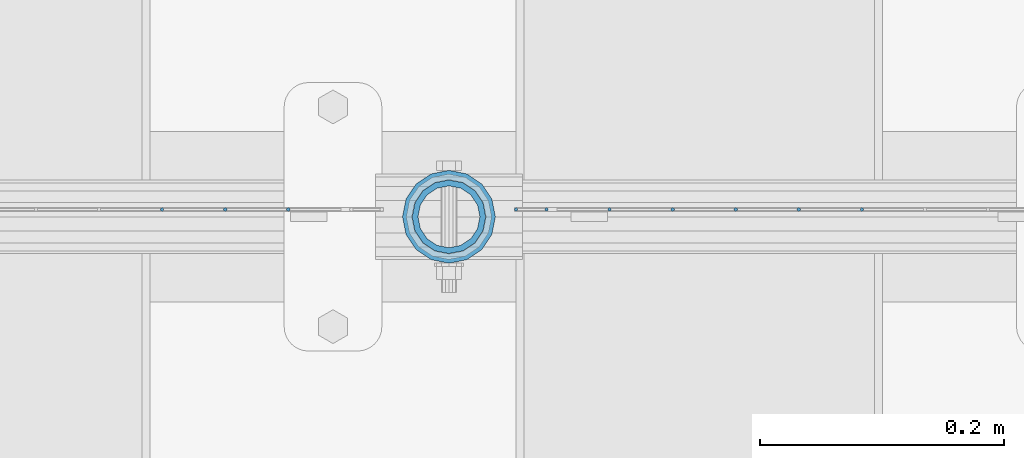
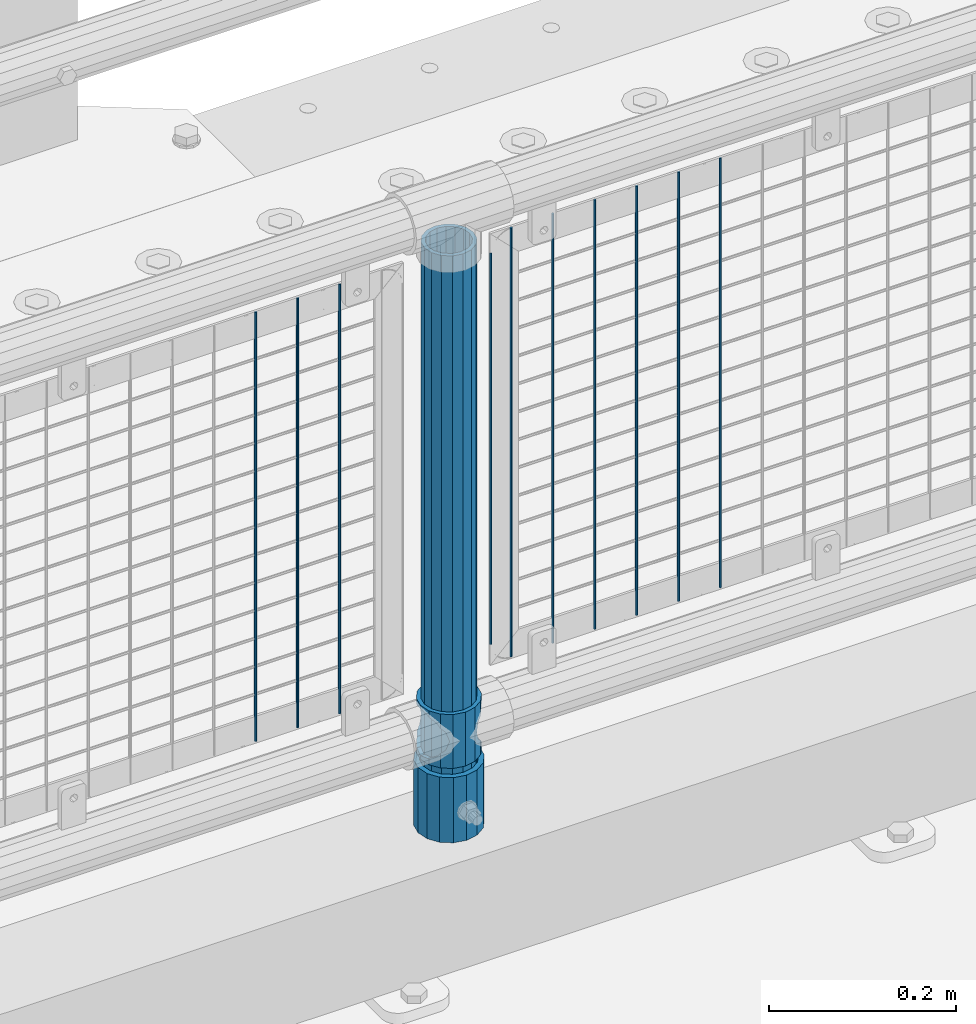
# One storey, part 63 of 193: 13 columns.
"""IFC2X3 building model written with IfcOpenShell, lengths in millimetres."""

from ifc_helpers import new_model, si_unit, frame, origin_with_axes, place, context, subcontext, project, spatial, faceted_brep, material, type_object, element, save


model = new_model("IFC2X3")

# Units and contexts
model_context = context("Model", 3, precision=1e-05, world=origin_with_axes())
body_context = subcontext(model_context, "Body", "Model", "MODEL_VIEW")
ifc_project = project(units=[si_unit("LENGTHUNIT", "METRE", prefix="MILLI"), si_unit("AREAUNIT", "SQUARE_METRE"), si_unit("VOLUMEUNIT", "CUBIC_METRE"), si_unit("MASSUNIT", "GRAM", prefix="KILO"), si_unit("TIMEUNIT", "SECOND"), si_unit("PLANEANGLEUNIT", "RADIAN"), si_unit("SOLIDANGLEUNIT", "STERADIAN"), si_unit("THERMODYNAMICTEMPERATUREUNIT", "DEGREE_CELSIUS"), si_unit("LUMINOUSINTENSITYUNIT", "LUMEN")], contexts=[model_context])

# Site, building, storey
site_placement = place(None, origin_with_axes())
site = spatial("IfcSite", under=ifc_project, at=site_placement, CompositionType="ELEMENT")
building_placement = place(site_placement, origin_with_axes())
building = spatial("IfcBuilding", under=site, at=building_placement, Name="Standard", CompositionType="ELEMENT")
storey_placement = place(building_placement, origin_with_axes())
storey = spatial("IfcBuildingStorey", under=building, at=storey_placement, Name="Undefined", CompositionType="ELEMENT", Elevation=0.0)

# Columns
ifc_material_1 = material(Name="Misc_Undefined")
column_type_1 = type_object("IfcColumnType", PredefinedType="NOTDEFINED")
column_1_placement = place(storey_placement, frame((-36855.0, 28664.5, 263.020000000001), z_axis=(-1.0, 0.0, 0.0), x_axis=(0.0, 0.0, 1.0)))
element("IfcColumn", 1, at=column_1_placement, inside=storey, type_object=column_type_1, material=ifc_material_1, context=body_context, shape_type="Brep", body=[
    faceted_brep([(56.6106908090114, 21.46069080901, -21.46069080901), (56.6106908090114, 21.46069080901, -27.1226768591041), (61.9623795176744, 13.4513226476338, -32.4743655677703), (63.1897438117172, 11.614442172282, -32.8397438117245), (63.1897438117172, 11.614442172282, -28.0397438117179), (46.7644421722801, 28.0397438117179, -11.614442172282), (46.7644421722801, 28.0397438117179, -20.0882031229849), (51.5310424080006, 24.8548033587067, -24.8548033587067), (35.1500000000015, 30.35, 0.0), (35.1499999999996, 30.3499999999985, -16.6306603983685), (23.5355578277192, 28.0397438117179, -11.614442172282), (23.5355578277192, 28.0397438117179, -20.0882031229849), (13.6893091909879, 21.46069080901, -21.46069080901), (13.6893091909879, 21.46069080901, -27.1226768591041), (18.7689575919987, 24.8548033587067, -24.8548033587067), (7.11025618828211, 11.614442172282, -28.0397438117179), (7.11025618828211, 11.614442172282, -32.8397438117245), (8.33762048232262, 13.4513226476338, -32.4743655677703), (4.79999999999961, 0.0, -30.3499999999985), (4.79999999999961, 0.0, -35.1500000000015), (7.11025618828211, -11.614442172282, -28.0397438117179), (7.11025618828211, -11.614442172282, -32.8397438117172), (13.6893091909879, -21.46069080901, -21.46069080901), (13.6893091909879, -21.46069080901, -27.1226768591114), (8.33762048232484, -13.4513226476338, -32.4743655677703), (23.5355578277191, -28.0397438117179, -11.614442172282), (23.5355578277191, -28.0397438117179, -20.0882031229812), (18.7689575919921, -24.8548033587067, -24.8548033587067), (35.1500000000015, -30.35, 0.0), (35.1499999999996, -30.3499999999985, -16.6306603983721), (46.7644421722801, -28.0397438117179, -11.614442172282), (46.7644421722801, -28.0397438117179, -20.0882031229812), (56.6106908090114, -21.46069080901, -21.46069080901), (56.6106908090114, -21.46069080901, -27.1226768591114), (51.5310424080006, -24.8548033587067, -24.8548033587067), (63.1897438117172, -11.614442172282, -28.0397438117179), (63.1897438117172, -11.614442172282, -32.8397438117172), (61.9623795176767, -13.4513226476338, -32.4743655677703), (65.4999999999997, 0.0, -30.3499999999985), (65.4999999999997, 0.0, -35.1500000000015), (0.0, -28.0397438117179, -11.614442172282), (0.0, -30.3499999999985, 0.0), (0.0, -21.46069080901, -21.46069080901), (0.0, -11.614442172282, -28.0397438117179), (0.0, 0.0, -30.3499999999985), (0.0, 11.614442172282, -28.0397438117179), (0.0, 21.46069080901, -21.46069080901), (0.0, 28.0397438117179, -11.614442172282), (0.0, 30.3499999999985, 0.0), (0.0, 28.0397438117179, 11.614442172282), (23.5355578277192, 28.0397438117179, 11.614442172282), (0.0, 21.46069080901, 21.46069080901), (13.6893091909879, 21.46069080901, 21.46069080901), (0.0, 11.614442172282, 28.0397438117179), (7.11025618828211, 11.614442172282, 28.0397438117179), (0.0, 0.0, 30.3499999999985), (4.79999999999961, 0.0, 30.3499999999985), (0.0, -11.614442172282, 28.0397438117179), (7.11025618828205, -11.614442172282, 28.0397438117179), (0.0, -21.46069080901, 21.46069080901), (13.6893091909879, -21.46069080901, 21.46069080901), (0.0, -28.0397438117179, 11.614442172282), (23.5355578277191, -28.0397438117179, 11.614442172282), (0.0, -32.4743655677703, 13.4513226476338), (0.0, -35.1500000000015, 0.0), (70.2999999999993, -35.1500000000015, 0.0), (70.2999999999993, -32.4743655677703, 13.4513226476338), (0.0, 13.4513226476338, -32.4743655677703), (0.0, 24.8548033587067, -24.8548033587067), (0.0, 0.0, -35.1500000000015), (0.0, -13.4513226476338, -32.4743655677703), (0.0, -24.8548033587067, -24.8548033587067), (0.0, -24.8548033587067, 24.8548033587067), (0.0, -13.4513226476338, 32.4743655677703), (0.0, 0.0, 35.1500000000015), (0.0, 13.4513226476338, 32.4743655677703), (0.0, 24.8548033587067, 24.8548033587067), (0.0, 32.4743655677703, 13.4513226476338), (0.0, 35.1500000000015, 0.0), (0.0, 32.4743655677703, -13.4513226476338), (0.0, -32.4743655677703, -13.4513226476338), (70.2999999999993, 32.4743655677703, 13.4513226476338), (70.2999999999993, 35.1500000000015, 0.0), (70.2999999999993, 32.4743655677703, -13.4513226476338), (70.2999999999993, 24.8548033587067, -24.8548033587067), (70.2999999999993, 13.4513226476338, -32.4743655677703), (70.2999999999993, 0.0, -35.1500000000015), (70.2999999999993, -13.4513226476338, -32.4743655677703), (70.2999999999993, -24.8548033587067, -24.8548033587067), (70.2999999999993, -32.4743655677703, -13.4513226476338), (70.2999999999993, 28.0397438117179, 11.614442172282), (70.2999999999993, 21.46069080901, 21.46069080901), (56.6106908090114, 21.46069080901, 21.46069080901), (46.7644421722801, 28.0397438117179, 11.614442172282), (70.2999999999993, 11.614442172282, 28.0397438117179), (63.1897438117172, 11.614442172282, 28.0397438117179), (70.2999999999993, 0.0, 30.3499999999985), (65.4999999999997, 0.0, 30.3499999999985), (70.2999999999993, -11.614442172282, 28.0397438117179), (63.1897438117172, -11.614442172282, 28.0397438117179), (70.2999999999993, -21.46069080901, 21.46069080901), (56.6106908090114, -21.46069080901, 21.46069080901), (70.2999999999993, -28.0397438117179, 11.614442172282), (46.7644421722801, -28.0397438117179, 11.614442172282), (70.2999999999993, -11.614442172282, -28.0397438117179), (70.2999999999993, 0.0, -30.3499999999985), (70.2999999999993, -21.46069080901, -21.46069080901), (70.2999999999993, -28.0397438117179, -11.614442172282), (70.2999999999993, -30.3499999999985, 0.0), (70.2999999999993, 24.8548033587067, 24.8548033587067), (70.2999999999993, 13.4513226476338, 32.4743655677703), (70.2999999999993, 0.0, 35.1500000000015), (70.2999999999993, -13.4513226476338, 32.4743655677703), (70.2999999999993, -24.8548033587067, 24.8548033587067), (70.2999999999993, 30.3499999999985, 0.0), (70.2999999999993, 28.0397438117179, -11.614442172282), (70.2999999999993, 21.46069080901, -21.46069080901), (70.2999999999993, 11.614442172282, -28.0397438117179), (61.9623795176742, 13.4513226476338, 32.4743655677703), (51.5310424080006, 24.8548033587067, 24.8548033587067), (56.6106908090114, 21.46069080901, 27.1226768591077), (65.4999999999997, 0.0, 35.1500000000015), (63.1897438117172, 11.614442172282, 32.8397438117136), (63.1897438117172, -11.614442172282, 32.8397438117136), (61.9623795176767, -13.4513226476338, 32.4743655677703), (56.6106908090114, -21.46069080901, 27.1226768591041), (51.5310424080006, -24.8548033587067, 24.8548033587067), (18.7689575919921, -24.8548033587067, 24.8548033587067), (46.7644421722801, -28.0397438117179, 20.0882031229812), (35.1499999999996, -30.3499999999985, 16.6306603983685), (23.5355578277191, -28.0397438117179, 20.0882031229812), (8.33762048232512, -13.4513226476338, 32.4743655677703), (13.6893091909879, -21.46069080901, 27.1226768591041), (4.79999999999961, 0.0, 35.1500000000015), (7.11025618828205, -11.614442172282, 32.8397438117136), (7.11025618828211, 11.614442172282, 32.8397438117136), (8.3376204823229, 13.4513226476338, 32.4743655677703), (13.6893091909879, 21.46069080901, 27.1226768591077), (18.7689575919987, 24.8548033587067, 24.8548033587067), (23.5355578277192, 28.0397438117179, 20.0882031229739), (35.1499999999996, 30.3499999999985, 16.6306603983576), (46.7644421722801, 28.0397438117179, 20.0882031229739)], [[[0, 1, 2, 3, 4]], [[5, 6, 7, 1, 0]], [[8, 9, 6, 5]], [[10, 11, 9, 8]], [[12, 13, 14, 11, 10]], [[15, 16, 17, 13, 12]], [[18, 19, 16, 15]], [[20, 21, 19, 18]], [[22, 23, 24, 21, 20]], [[25, 26, 27, 23, 22]], [[28, 29, 26, 25]], [[30, 31, 29, 28]], [[32, 33, 34, 31, 30]], [[35, 36, 37, 33, 32]], [[38, 39, 36, 35]], [[4, 3, 39, 38]], [[40, 41, 28, 25]], [[42, 40, 25, 22]], [[43, 42, 22, 20]], [[44, 43, 20, 18]], [[45, 44, 18, 15]], [[46, 45, 15, 12]], [[47, 46, 12, 10]], [[48, 47, 10, 8]], [[49, 48, 8, 50]], [[51, 49, 50, 52]], [[53, 51, 52, 54]], [[55, 53, 54, 56]], [[57, 55, 56, 58]], [[59, 57, 58, 60]], [[61, 59, 60, 62]], [[41, 61, 62, 28]], [[63, 64, 65, 66]], [[17, 67, 68, 14, 13]], [[19, 69, 67, 17, 16]], [[70, 69, 19, 21, 24]], [[71, 70, 24, 23, 27]], [[63, 72, 73, 74, 75, 76, 77, 78, 79, 68, 67, 69, 70, 71, 80, 64], [40, 42, 43, 44, 45, 46, 47, 48, 49, 51, 53, 55, 57, 59, 61, 41]], [[78, 77, 81, 82]], [[79, 78, 82, 83]], [[14, 68, 79, 83, 84, 7, 6, 9, 11]], [[84, 85, 2, 1, 7]], [[85, 86, 39, 3, 2]], [[37, 87, 88, 34, 33]], [[39, 86, 87, 37, 36]], [[34, 88, 89, 80, 71, 27, 26, 29, 31]], [[64, 80, 89, 65]], [[90, 91, 92, 93]], [[91, 94, 95, 92]], [[94, 96, 97, 95]], [[96, 98, 99, 97]], [[98, 100, 101, 99]], [[100, 102, 103, 101]], [[104, 105, 38, 35]], [[106, 104, 35, 32]], [[107, 106, 32, 30]], [[108, 107, 30, 28]], [[102, 108, 28, 103]], [[88, 87, 86, 85, 84, 83, 82, 81, 109, 110, 111, 112, 113, 66, 65, 89], [100, 98, 96, 94, 91, 90, 114, 115, 116, 117, 105, 104, 106, 107, 108, 102]], [[118, 110, 109, 119, 120]], [[121, 111, 110, 118, 122]], [[112, 111, 121, 123, 124]], [[113, 112, 124, 125, 126]], [[127, 72, 63, 66, 113, 126, 128, 129, 130]], [[131, 73, 72, 127, 132]], [[133, 74, 73, 131, 134]], [[75, 74, 133, 135, 136]], [[76, 75, 136, 137, 138]], [[119, 109, 81, 77, 76, 138, 139, 140, 141]], [[92, 120, 119, 141, 93]], [[95, 122, 118, 120, 92]], [[97, 121, 122, 95]], [[99, 123, 121, 97]], [[101, 125, 124, 123, 99]], [[103, 128, 126, 125, 101]], [[28, 129, 128, 103]], [[62, 130, 129, 28]], [[60, 132, 127, 130, 62]], [[58, 134, 131, 132, 60]], [[56, 133, 134, 58]], [[54, 135, 133, 56]], [[52, 137, 136, 135, 54]], [[50, 139, 138, 137, 52]], [[8, 140, 139, 50]], [[93, 141, 140, 8]], [[114, 90, 93, 8]], [[115, 114, 8, 5]], [[116, 115, 5, 0]], [[117, 116, 0, 4]], [[105, 117, 4, 38]]]),
])
ifc_material_2 = material()
column_type_2 = type_object("IfcColumnType", PredefinedType="NOTDEFINED")
column_2_placement = place(storey_placement, frame((-36855.0, 28664.5, 168.02), z_axis=(-1.0, 0.0, 0.0), x_axis=(0.0, 0.0, 1.0)))
element("IfcColumn", 2, at=column_2_placement, inside=storey, type_object=column_type_2, material=ifc_material_2, context=body_context, shape_type="Brep", body=[
    faceted_brep([(0.0, -25.3499999999985, 0.0), (0.0, -23.4203461491597, 9.70102501045403), (760.0, -23.4203461491597, 9.70102501045403), (760.0, -25.3499999999985, 0.0), (0.0, -17.9251569030785, 17.9251569030785), (760.0, -17.9251569030785, 17.9251569030785), (0.0, -9.70102501045403, 23.4203461491597), (760.0, -9.70102501045403, 23.4203461491597), (0.0, 0.0, 25.3499999999985), (760.0, 0.0, 25.3499999999985), (0.0, 9.70102501045403, 23.4203461491597), (760.0, 9.70102501045403, 23.4203461491597), (0.0, 17.9251569030785, 17.9251569030785), (760.0, 17.9251569030785, 17.9251569030785), (0.0, 23.4203461491597, 9.70102501045403), (760.0, 23.4203461491597, 9.70102501045403), (0.0, 25.3499999999985, 0.0), (760.0, 25.3499999999985, 0.0), (0.0, 23.4203461491597, -9.70102501045403), (760.0, 23.4203461491597, -9.70102501045403), (0.0, 17.9251569030785, -17.9251569030785), (760.0, 17.9251569030785, -17.9251569030785), (0.0, 9.70102501045403, -23.4203461491597), (760.0, 9.70102501045403, -23.4203461491597), (0.0, 0.0, -25.3499999999985), (760.0, 0.0, -25.3499999999985), (0.0, -9.70102501045403, -23.4203461491597), (760.0, -9.70102501045403, -23.4203461491597), (0.0, -17.9251569030785, -17.9251569030785), (760.0, -17.9251569030785, -17.9251569030785), (0.0, -23.4203461491597, -9.70102501045403), (760.0, -23.4203461491597, -9.70102501045403), (0.0, -30.1500000000015, 0.0), (0.0, -27.8549679052157, -11.5379054858058), (760.0, -27.8549679052157, -11.5379054858058), (760.0, -30.1500000000015, 0.0), (0.0, -21.3192694527752, -21.3192694527752), (760.0, -21.3192694527752, -21.3192694527752), (0.0, -11.5379054858058, -27.8549679052157), (760.0, -11.5379054858058, -27.8549679052157), (0.0, 0.0, -30.1500000000015), (760.0, 0.0, -30.1500000000015), (0.0, 11.5379054858058, -27.8549679052157), (760.0, 11.5379054858058, -27.8549679052157), (0.0, 21.3192694527752, -21.3192694527752), (760.0, 21.3192694527752, -21.3192694527752), (0.0, 27.8549679052157, -11.5379054858058), (760.0, 27.8549679052157, -11.5379054858058), (0.0, 30.1500000000015, 0.0), (760.0, 30.1500000000015, 0.0), (0.0, 27.8549679052157, 11.5379054858058), (760.0, 27.8549679052157, 11.5379054858058), (0.0, 21.3192694527752, 21.3192694527752), (760.0, 21.3192694527752, 21.3192694527752), (0.0, 11.5379054858058, 27.8549679052157), (760.0, 11.5379054858058, 27.8549679052157), (0.0, 0.0, 30.1500000000015), (760.0, 0.0, 30.1500000000015), (0.0, -11.5379054858058, 27.8549679052157), (760.0, -11.5379054858058, 27.8549679052157), (0.0, -21.3192694527752, 21.3192694527752), (760.0, -21.3192694527752, 21.3192694527752), (0.0, -27.8549679052157, 11.5379054858058), (760.0, -27.8549679052157, 11.5379054858058)], [[[0, 1, 2, 3]], [[1, 4, 5, 2]], [[4, 6, 7, 5]], [[6, 8, 9, 7]], [[8, 10, 11, 9]], [[10, 12, 13, 11]], [[12, 14, 15, 13]], [[14, 16, 17, 15]], [[16, 18, 19, 17]], [[18, 20, 21, 19]], [[20, 22, 23, 21]], [[22, 24, 25, 23]], [[24, 26, 27, 25]], [[26, 28, 29, 27]], [[28, 30, 31, 29]], [[30, 0, 3, 31]], [[32, 33, 34, 35]], [[33, 36, 37, 34]], [[36, 38, 39, 37]], [[38, 40, 41, 39]], [[40, 42, 43, 41]], [[42, 44, 45, 43]], [[44, 46, 47, 45]], [[46, 48, 49, 47]], [[48, 50, 51, 49]], [[50, 52, 53, 51]], [[52, 54, 55, 53]], [[54, 56, 57, 55]], [[56, 58, 59, 57]], [[58, 60, 61, 59]], [[60, 62, 63, 61]], [[62, 32, 35, 63]], [[37, 39, 41, 43, 45, 47, 49, 51, 53, 55, 57, 59, 61, 63, 35, 34], [5, 7, 9, 11, 13, 15, 17, 19, 21, 23, 25, 27, 29, 31, 3, 2]], [[62, 60, 58, 56, 54, 52, 50, 48, 46, 44, 42, 40, 38, 36, 33, 32], [30, 28, 26, 24, 22, 20, 18, 16, 14, 12, 10, 8, 6, 4, 1, 0]]]),
])
column_type_3 = type_object("IfcColumnType", PredefinedType="NOTDEFINED")
column_3_placement = place(storey_placement, frame((-36855.0, 28664.5, 168.02), z_axis=(0.0, 1.0, 0.0), x_axis=(0.0, 0.0, 1.0)))
element("IfcColumn", 3, at=column_3_placement, inside=storey, type_object=column_type_3, material=ifc_material_2, context=body_context, shape_type="Brep", body=[
    faceted_brep([(0.0, -31.75, 0.0), (0.0, -29.3331751572332, 12.1501989775934), (85.0, -29.3331751572332, 12.1501989775934), (85.0, -31.75, 0.0), (0.0, -22.4506403026717, 22.4506403026717), (85.0, -22.4506403026717, 22.4506403026717), (0.0, -12.1501989775934, 29.3331751572332), (85.0, -12.1501989775934, 29.3331751572332), (0.0, 0.0, 31.75), (85.0, 0.0, 31.75), (0.0, 12.1501989775934, 29.3331751572332), (85.0, 12.1501989775934, 29.3331751572332), (0.0, 22.4506403026717, 22.4506403026717), (85.0, 22.4506403026717, 22.4506403026717), (0.0, 29.3331751572332, 12.1501989775934), (85.0, 29.3331751572332, 12.1501989775934), (0.0, 31.75, 0.0), (85.0, 31.75, 0.0), (0.0, 29.3331751572332, -12.1501989775934), (85.0, 29.3331751572332, -12.1501989775934), (0.0, 22.4506403026717, -22.4506403026717), (85.0, 22.4506403026717, -22.4506403026717), (0.0, 12.1501989775934, -29.3331751572332), (85.0, 12.1501989775934, -29.3331751572332), (0.0, 0.0, -31.75), (85.0, 0.0, -31.75), (0.0, -12.1501989775934, -29.3331751572332), (85.0, -12.1501989775934, -29.3331751572332), (0.0, -22.4506403026717, -22.4506403026717), (85.0, -22.4506403026717, -22.4506403026717), (0.0, -29.3331751572332, -12.1501989775934), (85.0, -29.3331751572332, -12.1501989775934), (0.0, -38.0499999999993, 0.0), (0.0, -35.1536162120537, -14.5611046014928), (85.0, -35.1536162120537, -14.5611046014928), (85.0, -38.0499999999993, 0.0), (0.0, -26.9054130241493, -26.9054130241493), (85.0, -26.9054130241493, -26.9054130241493), (0.0, -14.5611046014928, -35.1536162120537), (85.0, -14.5611046014928, -35.1536162120537), (0.0, 0.0, -38.0499999999993), (85.0, 0.0, -38.0499999999993), (0.0, 14.5611046014928, -35.1536162120537), (85.0, 14.5611046014928, -35.1536162120537), (0.0, 26.9054130241493, -26.9054130241493), (85.0, 26.9054130241493, -26.9054130241493), (0.0, 35.1536162120537, -14.5611046014928), (85.0, 35.1536162120537, -14.5611046014928), (0.0, 38.0499999999993, 0.0), (85.0, 38.0499999999993, 0.0), (0.0, 35.1536162120537, 14.5611046014928), (85.0, 35.1536162120537, 14.5611046014928), (0.0, 26.9054130241493, 26.9054130241493), (85.0, 26.9054130241493, 26.9054130241493), (0.0, 14.5611046014928, 35.1536162120537), (85.0, 14.5611046014928, 35.1536162120537), (0.0, 0.0, 38.0499999999993), (85.0, 0.0, 38.0499999999993), (0.0, -14.5611046014928, 35.1536162120537), (85.0, -14.5611046014928, 35.1536162120537), (0.0, -26.9054130241493, 26.9054130241493), (85.0, -26.9054130241493, 26.9054130241493), (0.0, -35.1536162120537, 14.5611046014928), (85.0, -35.1536162120537, 14.5611046014928)], [[[0, 1, 2, 3]], [[1, 4, 5, 2]], [[4, 6, 7, 5]], [[6, 8, 9, 7]], [[8, 10, 11, 9]], [[10, 12, 13, 11]], [[12, 14, 15, 13]], [[14, 16, 17, 15]], [[16, 18, 19, 17]], [[18, 20, 21, 19]], [[20, 22, 23, 21]], [[22, 24, 25, 23]], [[24, 26, 27, 25]], [[26, 28, 29, 27]], [[28, 30, 31, 29]], [[30, 0, 3, 31]], [[32, 33, 34, 35]], [[33, 36, 37, 34]], [[36, 38, 39, 37]], [[38, 40, 41, 39]], [[40, 42, 43, 41]], [[42, 44, 45, 43]], [[44, 46, 47, 45]], [[46, 48, 49, 47]], [[48, 50, 51, 49]], [[50, 52, 53, 51]], [[52, 54, 55, 53]], [[54, 56, 57, 55]], [[56, 58, 59, 57]], [[58, 60, 61, 59]], [[60, 62, 63, 61]], [[62, 32, 35, 63]], [[37, 39, 41, 43, 45, 47, 49, 51, 53, 55, 57, 59, 61, 63, 35, 34], [5, 7, 9, 11, 13, 15, 17, 19, 21, 23, 25, 27, 29, 31, 3, 2]], [[62, 60, 58, 56, 54, 52, 50, 48, 46, 44, 42, 40, 38, 36, 33, 32], [30, 28, 26, 24, 22, 20, 18, 16, 14, 12, 10, 8, 6, 4, 1, 0]]]),
])
column_type_4 = type_object("IfcColumnType", Name="D3", PredefinedType="NOTDEFINED")
for number, where, z_axis, x_axis in (
    (4, (-36516.725, 28670.5, 353.02), (-1.0, 0.0, 0.0), (0.0, 0.0, 1.0)),
    (5, (-36568.38, 28670.5, 353.02), (-1.0, 0.0, 0.0), (0.0, 0.0, 1.0)),
    (6, (-36620.035, 28670.5, 353.02), (-1.0, 0.0, 0.0), (0.0, 0.0, 1.0)),
    (7, (-36671.69, 28670.5, 353.02), (-1.0, 0.0, 0.0), (0.0, 0.0, 1.0)),
    (8, (-36723.345, 28670.5, 353.02), (-1.0, 0.0, 0.0), (0.0, 0.0, 1.0)),
):
    element("IfcColumn", number, at=place(storey_placement, frame(where, z_axis=z_axis, x_axis=x_axis)), inside=storey, type_object=column_type_4, material=ifc_material_1, ObjectType="D3", context=body_context, shape_type="Brep", body=[
        faceted_brep([(0.0, -1.49999999999636, 3.63797880709171e-12), (0.0, -0.75, -1.29903810567669), (560.0, -0.75, -1.29903810567703), (560.0, -1.5, 0.0), (0.0, 0.75, -1.29903810567669), (560.0, 0.75, -1.29903810567703), (0.0, 1.50000000000364, 7.27595761418343e-12), (560.0, 1.5, 0.0), (0.0, 0.75, 1.29903810567669), (560.0, 0.75, 1.29903810567703), (0.0, -0.75, 1.29903810567669), (560.0, -0.75, 1.29903810567703)], [[[0, 1, 2, 3]], [[1, 4, 5, 2]], [[4, 6, 7, 5]], [[6, 8, 9, 7]], [[8, 10, 11, 9]], [[10, 0, 3, 11]], [[5, 7, 9, 11, 3, 2]], [[10, 8, 6, 4, 1, 0]]]),
    ])
column_4_placement = place(storey_placement, frame((-36800.0, 28670.5, 378.02), z_axis=(-1.0, 0.0, 0.0), x_axis=(0.0, 0.0, 1.0)))
element("IfcColumn", 9, at=column_4_placement, inside=storey, type_object=column_type_4, material=ifc_material_1, ObjectType="D3", context=body_context, shape_type="Brep", body=[
    faceted_brep([(0.0, -1.49999999999636, 3.63797880709171e-12), (0.0, -0.75, -1.29903810567669), (510.0, -0.75, -1.29903810567703), (510.0, -1.5, 0.0), (0.0, 0.75, -1.29903810567669), (510.0, 0.75, -1.29903810567703), (0.0, 1.50000000000364, 7.27595761418343e-12), (510.0, 1.5, 0.0), (0.0, 0.75, 1.29903810567669), (510.0, 0.75, 1.29903810567703), (0.0, -0.75, 1.29903810567669), (510.0, -0.75, 1.29903810567703)], [[[0, 1, 2, 3]], [[1, 4, 5, 2]], [[4, 6, 7, 5]], [[6, 8, 9, 7]], [[8, 10, 11, 9]], [[10, 0, 3, 11]], [[5, 7, 9, 11, 3, 2]], [[10, 8, 6, 4, 1, 0]]]),
])
for number, where, z_axis, x_axis in (
    (10, (-36775.0, 28670.5, 353.02), (-1.0, 0.0, 0.0), (0.0, 0.0, 1.0)),
    (11, (-36986.66, 28670.5, 353.02), (-1.0, 0.0, 0.0), (0.0, 0.0, 1.0)),
    (12, (-37038.315, 28670.5, 353.02), (-1.0, 0.0, 0.0), (0.0, 0.0, 1.0)),
    (13, (-37089.97, 28670.5, 353.02), (-1.0, 0.0, 0.0), (0.0, 0.0, 1.0)),
):
    element("IfcColumn", number, at=place(storey_placement, frame(where, z_axis=z_axis, x_axis=x_axis)), inside=storey, type_object=column_type_4, material=ifc_material_1, ObjectType="D3", context=body_context, shape_type="Brep", body=[
        faceted_brep([(0.0, -1.49999999999636, 3.63797880709171e-12), (0.0, -0.75, -1.29903810567669), (560.0, -0.75, -1.29903810567703), (560.0, -1.5, 0.0), (0.0, 0.75, -1.29903810567669), (560.0, 0.75, -1.29903810567703), (0.0, 1.50000000000364, 7.27595761418343e-12), (560.0, 1.5, 0.0), (0.0, 0.75, 1.29903810567669), (560.0, 0.75, 1.29903810567703), (0.0, -0.75, 1.29903810567669), (560.0, -0.75, 1.29903810567703)], [[[0, 1, 2, 3]], [[1, 4, 5, 2]], [[4, 6, 7, 5]], [[6, 8, 9, 7]], [[8, 10, 11, 9]], [[10, 0, 3, 11]], [[5, 7, 9, 11, 3, 2]], [[10, 8, 6, 4, 1, 0]]]),
    ])

save(model, "model.ifc")
